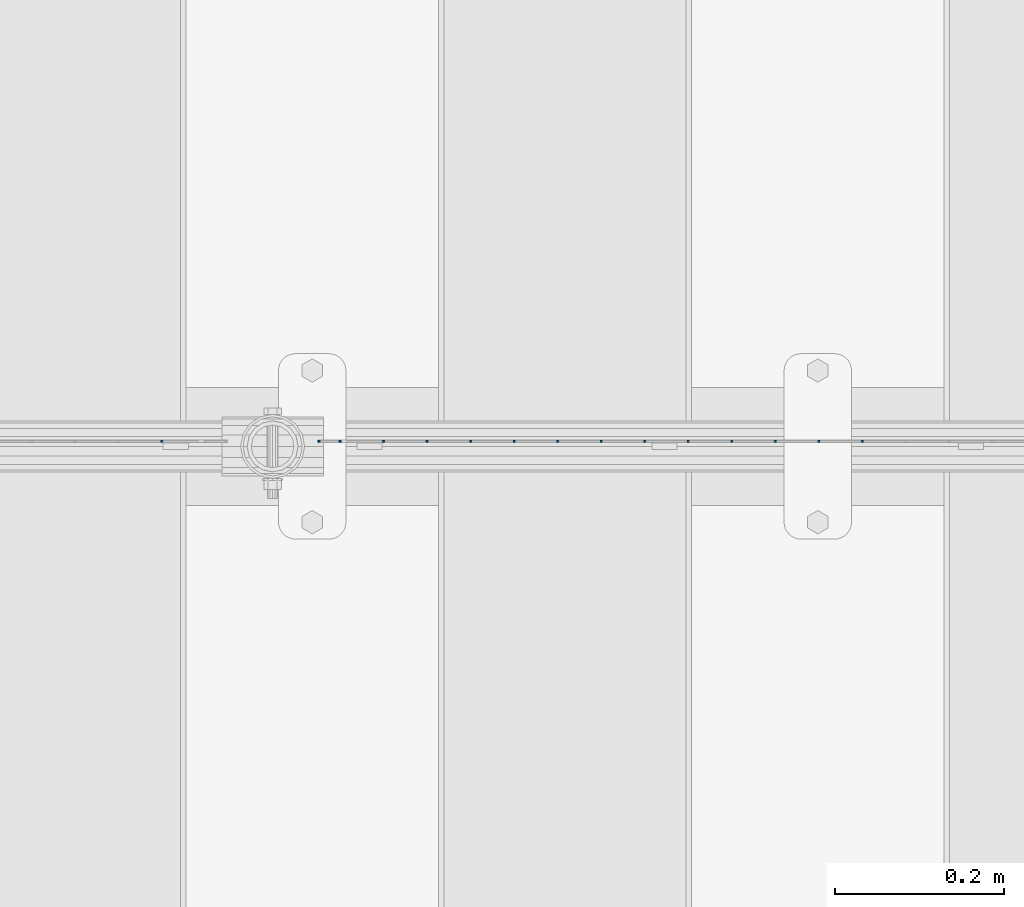
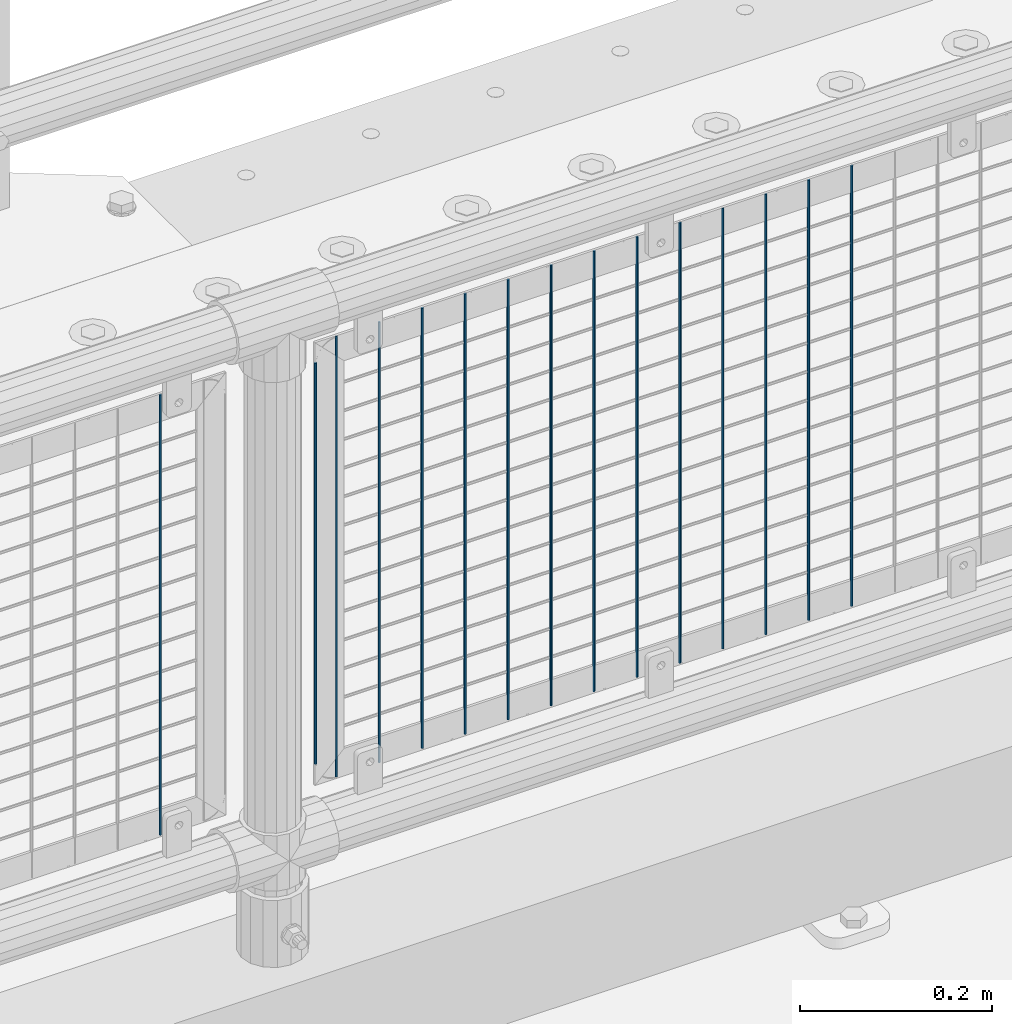
# One storey, part 79 of 219: 15 columns.
"""IFC2X3 building model written with IfcOpenShell, lengths in millimetres."""

from ifc_helpers import new_model, si_unit, frame, origin_with_axes, place, context, subcontext, project, spatial, faceted_brep, material, type_object, element, save


model = new_model("IFC2X3")

# Units and contexts
model_context = context("Model", 3, precision=1e-05, world=origin_with_axes())
body_context = subcontext(model_context, "Body", "Model", "MODEL_VIEW")
ifc_project = project(units=[si_unit("LENGTHUNIT", "METRE", prefix="MILLI"), si_unit("AREAUNIT", "SQUARE_METRE"), si_unit("VOLUMEUNIT", "CUBIC_METRE"), si_unit("MASSUNIT", "GRAM", prefix="KILO"), si_unit("TIMEUNIT", "SECOND"), si_unit("PLANEANGLEUNIT", "RADIAN"), si_unit("SOLIDANGLEUNIT", "STERADIAN"), si_unit("THERMODYNAMICTEMPERATUREUNIT", "DEGREE_CELSIUS"), si_unit("LUMINOUSINTENSITYUNIT", "LUMEN")], contexts=[model_context])

# Site, building, storey
site_placement = place(None, origin_with_axes())
site = spatial("IfcSite", under=ifc_project, at=site_placement, CompositionType="ELEMENT")
building_placement = place(site_placement, origin_with_axes())
building = spatial("IfcBuilding", under=site, at=building_placement, Name="Standard", CompositionType="ELEMENT")
storey_placement = place(building_placement, origin_with_axes())
storey = spatial("IfcBuildingStorey", under=building, at=storey_placement, Name="Undefined", CompositionType="ELEMENT", Elevation=0.0)

# Columns
ifc_material = material(Name="Misc_Undefined")
column_type = type_object("IfcColumnType", Name="D3", PredefinedType="NOTDEFINED")
for number, where, z_axis, x_axis in (
    (1, (7952.86, 31670.5, 353.020000000001), (-1.0, 0.0, 0.0), (0.0, 0.0, 1.0)),
    (2, (7901.205, 31670.5, 353.020000000001), (-1.0, 0.0, 0.0), (0.0, 0.0, 1.0)),
    (3, (7849.55, 31670.5, 353.020000000001), (-1.0, 0.0, 0.0), (0.0, 0.0, 1.0)),
    (4, (7797.895, 31670.5, 353.020000000001), (-1.0, 0.0, 0.0), (0.0, 0.0, 1.0)),
    (5, (7746.24, 31670.5, 353.020000000001), (-1.0, 0.0, 0.0), (0.0, 0.0, 1.0)),
    (6, (7694.585, 31670.5, 353.020000000001), (-1.0, 0.0, 0.0), (0.0, 0.0, 1.0)),
    (7, (7642.93, 31670.5, 353.020000000001), (-1.0, 0.0, 0.0), (0.0, 0.0, 1.0)),
    (8, (7591.275, 31670.5, 353.020000000001), (-1.0, 0.0, 0.0), (0.0, 0.0, 1.0)),
    (9, (7539.62, 31670.5, 353.020000000001), (-1.0, 0.0, 0.0), (0.0, 0.0, 1.0)),
    (10, (7487.965, 31670.5, 353.020000000001), (-1.0, 0.0, 0.0), (0.0, 0.0, 1.0)),
    (11, (7436.31, 31670.5, 353.020000000001), (-1.0, 0.0, 0.0), (0.0, 0.0, 1.0)),
    (12, (7384.655, 31670.5, 353.020000000001), (-1.0, 0.0, 0.0), (0.0, 0.0, 1.0)),
):
    element("IfcColumn", number, at=place(storey_placement, frame(where, z_axis=z_axis, x_axis=x_axis)), inside=storey, type_object=column_type, material=ifc_material, ObjectType="D3", context=body_context, shape_type="Brep", body=[
        faceted_brep([(0.0, -1.5, -5.6843418860808e-14), (0.0, -0.75, -1.29903810567669), (560.0, -0.75, -1.29903810567703), (560.0, -1.5, 0.0), (0.0, 0.75, -1.29903810567669), (560.0, 0.75, -1.29903810567703), (0.0, 1.5, -5.6843418860808e-14), (560.0, 1.5, 0.0), (0.0, 0.75, 1.29903810567669), (560.0, 0.75, 1.29903810567703), (0.0, -0.75, 1.29903810567669), (560.0, -0.75, 1.29903810567703)], [[[0, 1, 2, 3]], [[1, 4, 5, 2]], [[4, 6, 7, 5]], [[6, 8, 9, 7]], [[8, 10, 11, 9]], [[10, 0, 3, 11]], [[5, 7, 9, 11, 3, 2]], [[10, 8, 6, 4, 1, 0]]]),
    ])
column_placement = place(storey_placement, frame((7308.0, 31670.5, 378.020000000001), z_axis=(-1.0, 0.0, 0.0), x_axis=(0.0, 0.0, 1.0)))
element("IfcColumn", 13, at=column_placement, inside=storey, type_object=column_type, material=ifc_material, ObjectType="D3", context=body_context, shape_type="Brep", body=[
    faceted_brep([(0.0, -1.5, -5.6843418860808e-14), (0.0, -0.75, -1.29903810567669), (510.0, -0.75, -1.29903810567703), (510.0, -1.5, 0.0), (0.0, 0.75, -1.29903810567669), (510.0, 0.75, -1.29903810567703), (0.0, 1.5, -5.6843418860808e-14), (510.0, 1.5, 0.0), (0.0, 0.75, 1.29903810567669), (510.0, 0.75, 1.29903810567703), (0.0, -0.75, 1.29903810567669), (510.0, -0.75, 1.29903810567703)], [[[0, 1, 2, 3]], [[1, 4, 5, 2]], [[4, 6, 7, 5]], [[6, 8, 9, 7]], [[8, 10, 11, 9]], [[10, 0, 3, 11]], [[5, 7, 9, 11, 3, 2]], [[10, 8, 6, 4, 1, 0]]]),
])
for number, where, z_axis, x_axis in (
    (14, (7333.0, 31670.5, 353.020000000001), (-1.0, 0.0, 0.0), (0.0, 0.0, 1.0)),
    (15, (7121.34, 31670.5, 353.02), (-1.0, 0.0, 0.0), (0.0, 0.0, 1.0)),
):
    element("IfcColumn", number, at=place(storey_placement, frame(where, z_axis=z_axis, x_axis=x_axis)), inside=storey, type_object=column_type, material=ifc_material, ObjectType="D3", context=body_context, shape_type="Brep", body=[
        faceted_brep([(0.0, -1.5, -5.6843418860808e-14), (0.0, -0.75, -1.29903810567669), (560.0, -0.75, -1.29903810567703), (560.0, -1.5, 0.0), (0.0, 0.75, -1.29903810567669), (560.0, 0.75, -1.29903810567703), (0.0, 1.5, -5.6843418860808e-14), (560.0, 1.5, 0.0), (0.0, 0.75, 1.29903810567669), (560.0, 0.75, 1.29903810567703), (0.0, -0.75, 1.29903810567669), (560.0, -0.75, 1.29903810567703)], [[[0, 1, 2, 3]], [[1, 4, 5, 2]], [[4, 6, 7, 5]], [[6, 8, 9, 7]], [[8, 10, 11, 9]], [[10, 0, 3, 11]], [[5, 7, 9, 11, 3, 2]], [[10, 8, 6, 4, 1, 0]]]),
    ])

save(model, "model.ifc")
